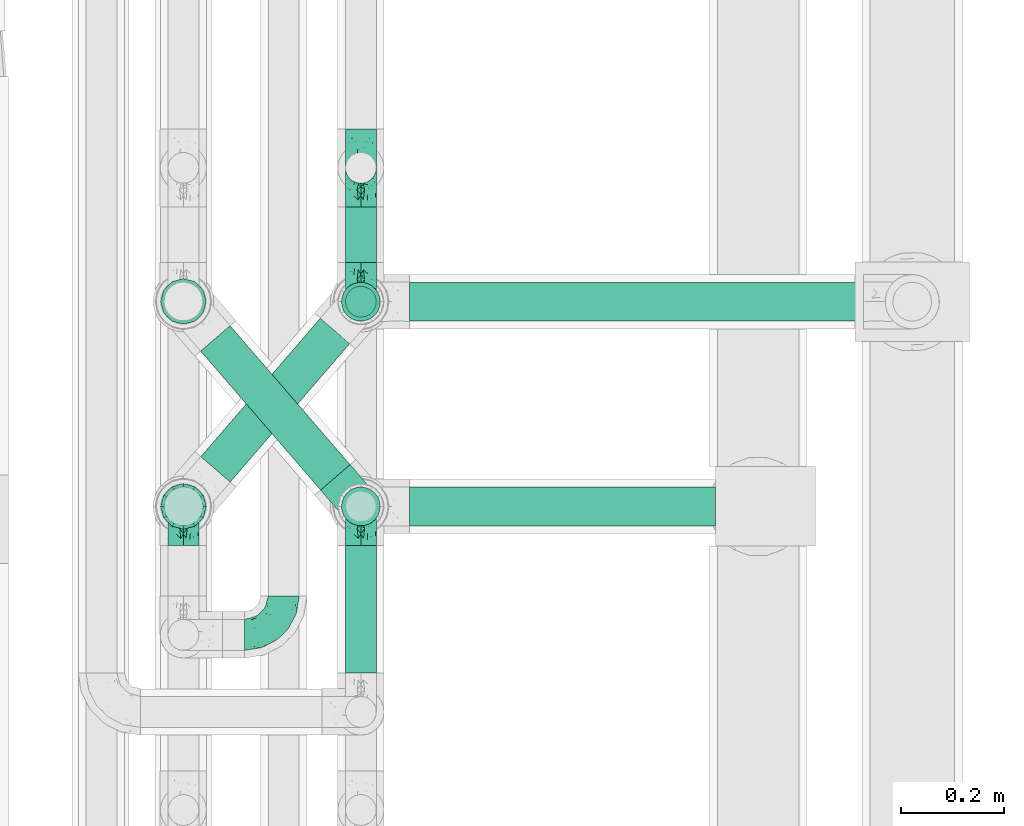
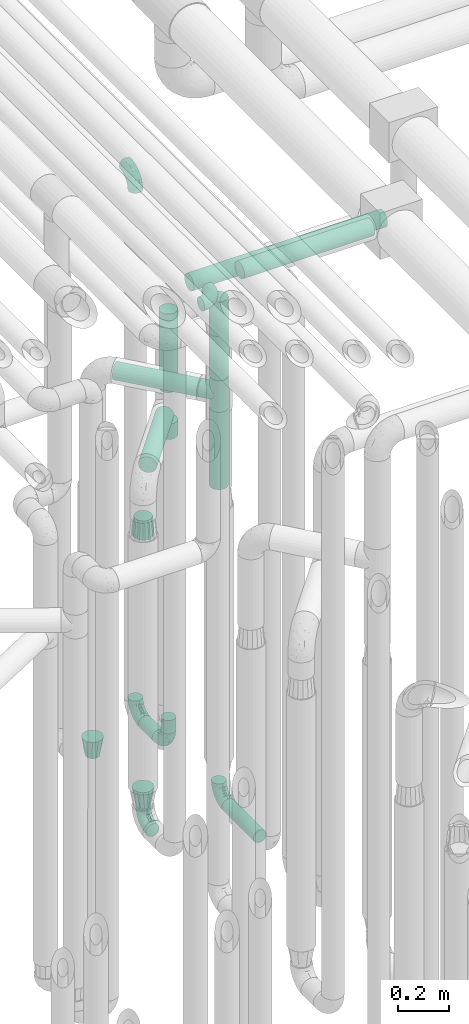
# One storey, part 624 of 824: 11 flow segments, 10 flow fittings.
"""IFC2X3 building model written with IfcOpenShell, lengths in millimetres."""

from ifc_helpers import new_model, entity, si_unit, converted_unit, derived_unit, direction, frame, origin, origin_2d_with_axis, place, context, subcontext, project, spatial, circle, extrude, faceted_brep, source, transform, mapped, material, type_object, type_shapes, element, save


model = new_model("IFC2X3")

# Units and contexts
model_context = context("Model", 3, precision=0.01, world=origin(), true_north=direction((6.12303176911189e-17, 1.0)))
body_context = subcontext(model_context, "Body", "Model", "MODEL_VIEW")
ifc_project = project(units=[si_unit("LENGTHUNIT", "METRE", prefix="MILLI"), si_unit("AREAUNIT", "SQUARE_METRE"), si_unit("VOLUMEUNIT", "CUBIC_METRE"), converted_unit("PLANEANGLEUNIT", "DEGREE", entity("IfcRatioMeasure", 0.0174532925199433), si_unit("PLANEANGLEUNIT", "RADIAN"), dimensions=[0, 0, 0, 0, 0, 0, 0]), si_unit("MASSUNIT", "GRAM", prefix="KILO"), derived_unit("MASSDENSITYUNIT", [(si_unit("MASSUNIT", "GRAM", prefix="KILO"), 1), (si_unit("LENGTHUNIT", "METRE"), -3)]), derived_unit("MOMENTOFINERTIAUNIT", [(si_unit("LENGTHUNIT", "METRE"), 4)]), si_unit("TIMEUNIT", "SECOND"), si_unit("FREQUENCYUNIT", "HERTZ"), si_unit("THERMODYNAMICTEMPERATUREUNIT", "DEGREE_CELSIUS"), derived_unit("THERMALTRANSMITTANCEUNIT", [(si_unit("MASSUNIT", "GRAM", prefix="KILO"), 1), (si_unit("THERMODYNAMICTEMPERATUREUNIT", "KELVIN"), -1), (si_unit("TIMEUNIT", "SECOND"), -3)]), derived_unit("VOLUMETRICFLOWRATEUNIT", [(si_unit("LENGTHUNIT", "METRE"), 3), (si_unit("TIMEUNIT", "SECOND"), -1)]), derived_unit("MASSFLOWRATEUNIT", [(si_unit("MASSUNIT", "GRAM", prefix="KILO"), 1), (si_unit("TIMEUNIT", "SECOND"), -1)]), derived_unit("ROTATIONALFREQUENCYUNIT", [(si_unit("TIMEUNIT", "SECOND"), -1)]), si_unit("ELECTRICCURRENTUNIT", "AMPERE"), si_unit("ELECTRICVOLTAGEUNIT", "VOLT"), si_unit("POWERUNIT", "WATT"), si_unit("FORCEUNIT", "NEWTON", prefix="KILO"), si_unit("ILLUMINANCEUNIT", "LUX"), si_unit("LUMINOUSFLUXUNIT", "LUMEN"), si_unit("LUMINOUSINTENSITYUNIT", "CANDELA"), derived_unit("USERDEFINED", [(si_unit("MASSUNIT", "GRAM", prefix="KILO"), -1), (si_unit("LENGTHUNIT", "METRE"), -2), (si_unit("TIMEUNIT", "SECOND"), 3), (si_unit("LUMINOUSFLUXUNIT", "LUMEN"), 1)]), derived_unit("LINEARVELOCITYUNIT", [(si_unit("LENGTHUNIT", "METRE"), 1), (si_unit("TIMEUNIT", "SECOND"), -1)]), si_unit("PRESSUREUNIT", "PASCAL"), derived_unit("USERDEFINED", [(si_unit("LENGTHUNIT", "METRE"), -2), (si_unit("MASSUNIT", "GRAM", prefix="KILO"), 1), (si_unit("TIMEUNIT", "SECOND"), -2)]), derived_unit("LINEARFORCEUNIT", [(si_unit("MASSUNIT", "GRAM", prefix="KILO"), 1), (si_unit("LENGTHUNIT", "METRE"), 1), (si_unit("TIMEUNIT", "SECOND"), -2), (si_unit("LENGTHUNIT", "METRE"), -1)]), derived_unit("PLANARFORCEUNIT", [(si_unit("MASSUNIT", "GRAM", prefix="KILO"), 1), (si_unit("LENGTHUNIT", "METRE"), 1), (si_unit("TIMEUNIT", "SECOND"), -2), (si_unit("LENGTHUNIT", "METRE"), -2)])], contexts=[model_context])

# Site, building, storey
site_placement = place(None, origin())
site = spatial("IfcSite", under=ifc_project, at=site_placement, CompositionType="ELEMENT")
building_placement = place(site_placement, origin())
building = spatial("IfcBuilding", under=site, at=building_placement, CompositionType="ELEMENT")
storey_placement = place(building_placement, frame((0.0, 0.0, 28200.0)))
storey = spatial("IfcBuildingStorey", under=building, at=storey_placement, CompositionType="ELEMENT", Elevation=28200.0)

# Flow segments
pipe_segment_type = type_object("IfcPipeSegmentType", PredefinedType="NOTDEFINED")
flow_segment_1_placement = place(storey_placement, frame((36943.44, 12257.17, 368.4)))
element("IfcFlowSegment", 1, at=flow_segment_1_placement, inside=storey, type_object=pipe_segment_type, context=body_context, shape_type="SweptSolid", body=[
    extrude(circle(Radius=30.0, at=origin_2d_with_axis()), frame((31.6, 0.0, 31.6), z_axis=(0.0, 1.0, 0.0), x_axis=(1.0, 0.0, 0.0)), (0.0, 0.0, 1.0), 247.999981999989),
])
flow_segment_2_placement = place(storey_placement, frame((36943.44, 13055.64, 368.4)))
element("IfcFlowSegment", 2, at=flow_segment_2_placement, inside=storey, type_object=pipe_segment_type, context=body_context, shape_type="SweptSolid", body=[
    extrude(circle(Radius=30.0, at=origin_2d_with_axis()), frame((31.6, 0.0, 31.6), z_axis=(0.0, 1.0, 0.0), x_axis=(-1.0, 0.0, 0.0)), (0.0, 0.0, 1.0), 108.562571608464),
])
flow_segment_3_placement = place(storey_placement, frame((36943.44, 12948.05, 476.0)))
element("IfcFlowSegment", 3, at=flow_segment_3_placement, inside=storey, type_object=pipe_segment_type, context=body_context, shape_type="SweptSolid", body=[
    extrude(circle(Radius=30.0, at=origin_2d_with_axis()), frame((31.6, 31.6, 0.0)), (0.0, 0.0, 1.0), 64.0000000000244),
])
flow_segment_4_placement = place(storey_placement, frame((36935.69, 12940.3, 2126.0)))
element("IfcFlowSegment", 4, at=flow_segment_4_placement, inside=storey, type_object=pipe_segment_type, context=body_context, shape_type="SweptSolid", body=[
    extrude(circle(Radius=37.75, at=origin_2d_with_axis()), frame((39.35, 39.35, 0.0), z_axis=(0.0, 0.0, 1.0), x_axis=(-1.0, 0.0, 0.0)), (0.0, 0.0, 1.0), 378.999999999992),
])
flow_segment_5_placement = place(storey_placement, frame((37070.03, 12940.3, 2560.65)))
element("IfcFlowSegment", 5, at=flow_segment_5_placement, inside=storey, type_object=pipe_segment_type, context=body_context, shape_type="SweptSolid", body=[
    extrude(circle(Radius=37.75, at=origin_2d_with_axis()), frame((0.0, 39.35, 39.35), z_axis=(1.0, 0.0, 0.0), x_axis=(0.0, -1.0, 0.0)), (0.0, 0.0, 1.0), 883.265688415884),
])
flow_segment_6_placement = place(storey_placement, frame((36935.69, 12541.83, 2426.0)))
element("IfcFlowSegment", 6, at=flow_segment_6_placement, inside=storey, type_object=pipe_segment_type, context=body_context, shape_type="SweptSolid", body=[
    extrude(circle(Radius=37.75, at=origin_2d_with_axis()), frame((39.35, 39.35, 0.0), z_axis=(-2.14503310068031e-08, 1.89574983412965e-07, 1.0), x_axis=(-1.0, 0.0, -2.14503310068034e-08)), (0.0, 0.0, 1.0), 378.904960794338),
])
flow_segment_7_placement = place(storey_placement, frame((37070.03, 12541.83, 2860.56)))
element("IfcFlowSegment", 7, at=flow_segment_7_placement, inside=storey, type_object=pipe_segment_type, context=body_context, shape_type="SweptSolid", body=[
    extrude(circle(Radius=37.75, at=origin_2d_with_axis()), frame((0.0, 39.35, 39.35), z_axis=(1.0, 0.0, 0.0), x_axis=(0.0, 1.0, 0.0)), (0.0, 0.0, 1.0), 595.765098762424),
])
flow_segment_8_placement = place(storey_placement, frame((36661.57, 12611.47, 2310.65)))
element("IfcFlowSegment", 8, at=flow_segment_8_placement, inside=storey, type_object=pipe_segment_type, context=body_context, shape_type="SweptSolid", body=[
    extrude(circle(Radius=37.75, at=origin_2d_with_axis()), frame((30.17, 296.83, 39.35), z_axis=(0.65359148401651, -0.756847522306242, 0.0), x_axis=(-0.756847522306242, -0.65359148401651, 0.0)), (0.0, 0.0, 1.0), 357.482862990724),
])
flow_segment_9_placement = place(storey_placement, frame((36935.69, 12541.83, 1900.0)))
element("IfcFlowSegment", 9, at=flow_segment_9_placement, inside=storey, type_object=pipe_segment_type, context=body_context, shape_type="SweptSolid", body=[
    extrude(circle(Radius=37.75, at=origin_2d_with_axis()), frame((39.35, 39.35, 0.0), z_axis=(0.0, 0.0, 1.0), x_axis=(-1.0, 0.0, 0.0)), (0.0, 0.0, 1.0), 374.000000000002),
])
flow_segment_10_placement = place(storey_placement, frame((36661.85, 12626.98, 2010.65)))
element("IfcFlowSegment", 10, at=flow_segment_10_placement, inside=storey, type_object=pipe_segment_type, context=body_context, shape_type="SweptSolid", body=[
    extrude(circle(Radius=37.75, at=origin_2d_with_axis()), frame((30.17, 26.27, 39.35), z_axis=(0.653617255256322, 0.756825266247891, 0.0), x_axis=(0.756825266247891, -0.653617255256322, 0.0)), (0.0, 0.0, 1.0), 356.010747294406),
])
flow_segment_11_placement = place(storey_placement, frame((36935.69, 12940.3, 1900.0)))
element("IfcFlowSegment", 11, at=flow_segment_11_placement, inside=storey, type_object=pipe_segment_type, context=body_context, shape_type="SweptSolid", body=[
    extrude(circle(Radius=37.75, at=origin_2d_with_axis()), frame((39.35, 39.35, 0.0), z_axis=(0.0, 0.0, 1.0), x_axis=(-1.0, 0.0, 0.0)), (0.0, 0.0, 1.0), 74.0000000000005),
])

# Flow fittings
ifc_material = material()
pipe_fitting_type_1 = type_object("IfcPipeFittingType", PredefinedType="NOTDEFINED", material=ifc_material)
shared_shape_1 = source(origin(), body_context, "Body", "Brep", [
    faceted_brep([(-76.0, 15.07, -26.11), (-76.0, 7.8, -29.12), (-76.0, 0.0, -30.15), (-76.0, -7.8, -29.12), (-76.0, -15.08, -26.11), (-76.0, -21.32, -21.32), (-76.0, -26.11, -15.08), (-76.0, -29.12, -7.8), (-76.0, -30.15, 0.0), (-76.0, -29.12, 7.8), (-76.0, -26.11, 15.07), (-76.0, -21.32, 21.32), (-76.0, -15.08, 26.11), (-76.0, -7.8, 29.12), (-76.0, 0.0, 30.15), (-76.0, 7.8, 29.12), (-76.0, 15.07, 26.11), (-76.0, 21.32, 21.32), (-76.0, 26.11, 15.07), (-76.0, 29.12, 7.8), (-76.0, 30.15, 0.0), (-76.0, 29.12, -7.8), (-76.0, 26.11, -15.08), (-76.0, 21.32, -21.32), (0.0, 76.0, -30.15), (-7.8, 76.0, -29.12), (-15.07, 76.0, -26.11), (-21.32, 76.0, -21.32), (-26.11, 76.0, -15.08), (-29.12, 76.0, -7.8), (-30.15, 76.0, 0.0), (-29.12, 76.0, 7.8), (-26.11, 76.0, 15.07), (-21.32, 76.0, 21.32), (-15.07, 76.0, 26.11), (-7.8, 76.0, 29.12), (0.0, 76.0, 30.15), (7.8, 76.0, 29.12), (15.08, 76.0, 26.11), (21.32, 76.0, 21.32), (26.11, 76.0, 15.07), (29.12, 76.0, 7.8), (30.15, 76.0, 0.0), (29.12, 76.0, -7.8), (26.11, 76.0, -15.08), (21.32, 76.0, -21.32), (15.08, 76.0, -26.11), (7.8, 76.0, -29.12), (10.79, 31.43, 21.07), (4.32, 31.7, 25.72), (1.65, 15.19, 19.92), (-61.17, -27.8, 0.0), (-51.1, -25.49, 9.84), (-56.14, -10.61, 27.27), (-31.7, -4.32, 25.72), (-39.75, 1.72, 29.41), (-43.2, -24.95, 0.0), (-1.86, 1.86, 0.0), (4.49, 7.65, 5.78), (-7.82, -4.61, 5.83), (-56.21, -22.79, 17.21), (-58.98, -3.38, 29.7), (-53.96, 5.6, 30.07), (-10.86, 10.86, 25.48), (-17.2, -2.6, 20.44), (-49.15, -16.01, 22.7), (-22.18, -14.24, 7.99), (-28.4, -17.42, 0.0), (-13.61, -9.88, 0.0), (-39.0, 23.48, 27.76), (-58.76, 12.54, 28.36), (-41.61, 15.41, 29.48), (16.01, 49.15, 22.7), (-58.55, 25.93, 19.53), (-51.53, 33.5, 13.51), (-64.92, 28.76, 12.4), (-7.48, 23.14, 28.25), (-1.72, 39.75, 29.41), (-12.04, 27.88, 29.88), (-63.91, 18.81, 24.52), (-11.63, 65.16, 28.18), (-4.97, 57.02, 30.05), (9.88, 13.61, 0.0), (-62.5, 31.74, 5.02), (-45.17, 30.98, 21.2), (-21.78, 9.76, 28.58), (10.61, 56.14, 27.27), (-32.09, 54.42, 13.26), (22.79, 56.21, 17.21), (15.38, 31.17, 15.63), (25.49, 51.1, 9.84), (21.84, 36.35, 5.92), (24.95, 43.2, 0.0), (3.38, 58.98, 29.7), (-31.17, -15.38, 15.63), (-39.39, 41.78, 15.45), (-34.56, 41.13, 20.79), (-39.81, -23.25, 5.49), (27.8, 61.17, 0.0), (-31.74, 62.5, 5.02), (-53.07, 36.29, 0.0), (-42.95, 42.95, 7.29), (-36.29, 53.07, 0.0), (-19.83, 58.51, 24.79), (-25.48, 60.2, 19.41), (-14.53, 50.96, 28.57), (-13.31, 37.09, 30.07), (-26.16, 40.06, 26.4), (-32.43, -10.35, 21.9), (17.42, 28.4, 0.0), (14.24, 22.18, 7.99), (-38.67, 9.72, 30.15), (-24.66, 17.36, 30.09), (-37.08, 31.49, 24.99), (-49.27, 22.83, 25.24), (-20.8, 38.81, 28.63), (-27.58, 27.58, 29.2), (-36.07, -20.23, 10.71), (-15.19, -6.16, 14.9), (6.6, 15.4, 14.49), (-2.51, 2.51, 11.35), (-65.16, 11.63, -28.18), (-49.15, -16.01, -22.7), (-57.02, 4.97, -30.05), (-25.93, 58.55, -19.53), (-33.5, 51.53, -13.51), (-28.76, 64.92, -12.4), (-60.2, 25.48, -19.41), (-58.51, 19.83, -24.79), (4.61, 7.82, -5.83), (-7.65, -4.49, -5.78), (-2.51, 2.51, -11.35), (-62.5, 31.74, -5.02), (-50.96, 14.53, -28.57), (-37.09, 13.31, -30.07), (-42.95, 42.95, -7.29), (25.49, 51.1, -9.84), (22.79, 56.21, -17.21), (-40.06, 26.16, -26.4), (3.38, 58.98, -29.7), (-5.6, 53.96, -30.07), (-27.88, 12.04, -29.88), (-9.76, 21.78, -28.58), (-23.14, 7.48, -28.25), (-51.1, -25.49, -9.84), (15.38, 31.17, -15.63), (16.01, 49.15, -22.7), (-23.48, 39.0, -27.76), (-12.54, 58.76, -28.36), (-15.41, 41.61, -29.48), (-56.21, -22.79, -17.21), (-9.72, 38.67, -30.15), (-17.36, 24.66, -30.09), (-22.18, -14.24, -7.99), (-41.13, 34.56, -20.79), (-31.74, 62.5, -5.02), (-58.98, -3.38, -29.7), (-31.17, -15.38, -15.63), (-56.14, -10.61, -27.27), (14.24, 22.18, -7.99), (23.25, 39.81, -5.49), (-31.49, 37.08, -24.99), (-15.19, -6.16, -14.9), (1.65, 15.19, -19.92), (-18.81, 63.91, -24.52), (-32.59, -11.62, -20.84), (-31.7, -4.32, -25.72), (-17.2, -2.6, -20.44), (-39.75, 1.72, -29.41), (-54.42, 32.09, -13.26), (-30.98, 45.17, -21.2), (10.61, 56.14, -27.27), (10.23, 31.31, -21.52), (4.32, 31.7, -25.72), (-41.78, 39.39, -15.45), (-1.72, 39.75, -29.41), (-36.35, -21.84, -5.92), (-22.83, 49.27, -25.24), (-38.81, 20.8, -28.63), (-27.58, 27.58, -29.2), (-10.86, 10.86, -25.48), (20.23, 36.07, -10.71), (6.6, 15.4, -14.49)], [[[0, 1, 2, 3, 4, 5, 6, 7, 8, 9, 10, 11, 12, 13, 14, 15, 16, 17, 18, 19, 20, 21, 22, 23]], [[24, 25, 26, 27, 28, 29, 30, 31, 32, 33, 34, 35, 36, 37, 38, 39, 40, 41, 42, 43, 44, 45, 46, 47]], [[48, 49, 50]], [[51, 52, 9]], [[53, 54, 55]], [[9, 52, 10]], [[56, 52, 51]], [[57, 58, 59]], [[11, 10, 60]], [[14, 61, 62]], [[63, 54, 64]], [[65, 12, 11]], [[65, 53, 12]], [[66, 67, 68]], [[69, 70, 71]], [[72, 39, 38]], [[73, 74, 75]], [[15, 70, 16]], [[76, 77, 78]], [[16, 79, 17]], [[13, 61, 14]], [[35, 80, 81]], [[14, 62, 15]], [[17, 73, 18]], [[57, 82, 58]], [[20, 19, 83]], [[75, 19, 18]], [[70, 15, 62]], [[73, 84, 74]], [[78, 85, 76]], [[38, 86, 72]], [[32, 31, 87]], [[88, 89, 90]], [[91, 92, 90]], [[72, 86, 49]], [[36, 93, 37]], [[75, 83, 19]], [[36, 35, 81]], [[60, 94, 65]], [[40, 90, 41]], [[95, 96, 87]], [[88, 90, 40]], [[66, 97, 67]], [[90, 98, 41]], [[40, 39, 88]], [[99, 31, 30]], [[20, 83, 100]], [[101, 102, 100]], [[52, 60, 10]], [[102, 99, 30]], [[96, 103, 104]], [[83, 101, 100]], [[12, 53, 13]], [[104, 103, 33]], [[105, 106, 81]], [[107, 105, 103]], [[64, 54, 108]], [[80, 103, 105]], [[80, 35, 34]], [[34, 33, 103]], [[86, 38, 37]], [[109, 110, 82]], [[71, 111, 112]], [[69, 107, 113]], [[79, 73, 17]], [[114, 113, 84]], [[33, 32, 104]], [[115, 107, 116]], [[105, 115, 106]], [[93, 81, 77]], [[54, 53, 65]], [[61, 53, 55]], [[108, 94, 64]], [[54, 63, 85]], [[93, 86, 37]], [[77, 76, 49]], [[77, 49, 86]], [[49, 63, 50]], [[60, 52, 117]], [[65, 11, 60]], [[39, 72, 88]], [[89, 88, 72]], [[71, 70, 62]], [[79, 70, 114]], [[103, 96, 107]], [[69, 113, 114]], [[112, 106, 116]], [[77, 81, 106]], [[112, 116, 71]], [[112, 55, 85]], [[64, 50, 63]], [[57, 59, 68]], [[32, 87, 104]], [[96, 104, 87]], [[94, 118, 64]], [[50, 119, 89]], [[50, 64, 118]], [[50, 89, 48]], [[81, 93, 36]], [[86, 93, 77]], [[53, 61, 13]], [[62, 61, 55]], [[71, 62, 111]], [[69, 71, 116]], [[95, 101, 74]], [[99, 101, 87]], [[118, 66, 59]], [[117, 97, 66]], [[117, 66, 94]], [[91, 89, 110]], [[91, 110, 109]], [[110, 89, 119]], [[9, 8, 51]], [[98, 90, 92]], [[98, 42, 41]], [[101, 83, 74]], [[101, 99, 102]], [[87, 31, 99]], [[62, 55, 111]], [[55, 112, 111]], [[107, 69, 116]], [[70, 69, 114]], [[107, 96, 113]], [[84, 113, 96]], [[84, 96, 95]], [[114, 84, 73]], [[70, 79, 16]], [[73, 79, 114]], [[54, 85, 55]], [[76, 85, 63]], [[49, 76, 63]], [[77, 106, 78]], [[106, 112, 78]], [[85, 78, 112]], [[73, 75, 18]], [[83, 75, 74]], [[103, 80, 34]], [[81, 80, 105]], [[101, 95, 87]], [[84, 95, 74]], [[106, 115, 116]], [[105, 107, 115]], [[120, 59, 58]], [[82, 110, 58]], [[119, 58, 110]], [[118, 59, 120]], [[66, 68, 59]], [[54, 65, 108]], [[94, 108, 65]], [[66, 118, 94]], [[50, 118, 120]], [[50, 120, 119]], [[119, 120, 58]], [[89, 72, 48]], [[49, 48, 72]], [[60, 117, 94]], [[117, 52, 97]], [[52, 56, 97]], [[67, 97, 56]], [[92, 91, 109]], [[89, 91, 90]], [[121, 1, 0]], [[122, 5, 4]], [[2, 1, 123]], [[124, 125, 126]], [[127, 128, 23]], [[129, 130, 131]], [[100, 132, 20]], [[133, 134, 123]], [[135, 100, 102]], [[136, 137, 44]], [[133, 128, 138]], [[24, 139, 140]], [[141, 142, 143]], [[121, 128, 133]], [[6, 144, 7]], [[137, 145, 146]], [[144, 51, 7]], [[147, 148, 149]], [[144, 6, 150]], [[149, 151, 152]], [[153, 68, 67]], [[154, 128, 127]], [[30, 155, 102]], [[43, 42, 98]], [[156, 3, 2]], [[157, 144, 150]], [[158, 4, 3]], [[24, 140, 25]], [[155, 135, 102]], [[159, 160, 109]], [[30, 29, 155]], [[147, 138, 161]], [[27, 124, 28]], [[57, 129, 82]], [[162, 163, 131]], [[27, 26, 164]], [[148, 26, 25]], [[165, 166, 167]], [[24, 47, 139]], [[143, 168, 141]], [[22, 21, 169]], [[125, 124, 170]], [[148, 25, 140]], [[46, 146, 171]], [[158, 122, 4]], [[0, 23, 128]], [[1, 121, 123]], [[109, 82, 159]], [[45, 44, 137]], [[146, 46, 45]], [[136, 43, 98]], [[132, 21, 20]], [[136, 98, 92]], [[172, 173, 146]], [[46, 171, 47]], [[43, 136, 44]], [[174, 154, 169]], [[171, 173, 175]], [[6, 5, 150]], [[126, 29, 28]], [[176, 56, 144]], [[122, 158, 166]], [[164, 124, 27]], [[177, 161, 170]], [[23, 22, 127]], [[178, 138, 179]], [[133, 178, 134]], [[156, 123, 168]], [[156, 158, 3]], [[168, 143, 166]], [[168, 166, 158]], [[166, 180, 167]], [[173, 171, 146]], [[139, 171, 175]], [[172, 145, 163]], [[173, 180, 142]], [[5, 122, 150]], [[157, 150, 122]], [[137, 136, 181]], [[146, 45, 137]], [[149, 148, 140]], [[164, 148, 177]], [[128, 154, 138]], [[147, 161, 177]], [[152, 134, 179]], [[168, 123, 134]], [[152, 179, 149]], [[152, 175, 142]], [[57, 130, 129]], [[157, 165, 167]], [[22, 169, 127]], [[154, 127, 169]], [[163, 167, 180]], [[162, 157, 167]], [[173, 163, 180]], [[182, 163, 145]], [[123, 156, 2]], [[158, 156, 168]], [[171, 139, 47]], [[140, 139, 175]], [[149, 140, 151]], [[147, 149, 179]], [[174, 135, 125]], [[132, 135, 169]], [[176, 157, 153]], [[176, 153, 67]], [[153, 157, 162]], [[182, 159, 129]], [[181, 160, 159]], [[181, 159, 145]], [[51, 144, 56]], [[51, 8, 7]], [[135, 132, 100]], [[169, 21, 132]], [[126, 155, 29]], [[135, 155, 125]], [[140, 175, 151]], [[175, 152, 151]], [[138, 147, 179]], [[148, 147, 177]], [[138, 154, 161]], [[170, 161, 154]], [[170, 154, 174]], [[177, 170, 124]], [[148, 164, 26]], [[124, 164, 177]], [[173, 142, 175]], [[143, 142, 180]], [[166, 143, 180]], [[168, 134, 141]], [[134, 152, 141]], [[142, 141, 152]], [[124, 126, 28]], [[155, 126, 125]], [[128, 121, 0]], [[123, 121, 133]], [[135, 174, 169]], [[170, 174, 125]], [[134, 178, 179]], [[133, 138, 178]], [[130, 153, 162]], [[68, 153, 130]], [[57, 68, 130]], [[182, 129, 131]], [[159, 82, 129]], [[157, 122, 165]], [[166, 165, 122]], [[163, 162, 167]], [[162, 131, 130]], [[145, 172, 146]], [[163, 173, 172]], [[159, 182, 145]], [[131, 163, 182]], [[56, 176, 67]], [[157, 176, 144]], [[137, 181, 145]], [[181, 136, 160]], [[136, 92, 160]], [[109, 160, 92]]]),
])
type_shapes(pipe_fitting_type_1, [shared_shape_1])
for number, where, z_axis, x_axis in (
    (12, (36975.03, 12581.17, 400.0), (1.0, 0.0, 0.0), (0.0, 1.0, 0.0)),
    (13, (36975.03, 13240.2, 400.0), (-1.0, 0.0, 0.0), (0.0, 0.0, -1.0)),
    (14, (36975.03, 12979.64, 400.0), (-1.0, 0.0, 0.0), (0.0, -1.0, 0.0)),
    (15, (36975.03, 13240.2, 3000.0), (-1.0, 0.0, 0.0), (0.0, 0.0, 1.0)),
):
    element("IfcFlowFitting", number, at=place(storey_placement, frame(where, z_axis=z_axis, x_axis=x_axis)), inside=storey, type_object=pipe_fitting_type_1, material=ifc_material, context=body_context, shape_type="MappedRepresentation", body=[
        mapped(shared_shape_1, transform((0.0, 0.0, 0.0), scale=1.0)),
    ])
flow_fitting_1_placement = place(storey_placement, frame((36825.03, 12331.17, 3000.0)))
element("IfcFlowFitting", 16, at=flow_fitting_1_placement, inside=storey, type_object=pipe_fitting_type_1, material=ifc_material, context=body_context, shape_type="MappedRepresentation", body=[
    mapped(shared_shape_1, transform((0.0, 0.0, 0.0), scale=1.0)),
])
flow_fitting_2_placement = place(storey_placement, frame((36629.64, 12581.17, 400.0), z_axis=(0.999999979696238, 0.0, -0.000201513087664095), x_axis=(0.0, 1.0, 0.0)))
element("IfcFlowFitting", 17, at=flow_fitting_2_placement, inside=storey, type_object=pipe_fitting_type_1, material=ifc_material, context=body_context, shape_type="MappedRepresentation", body=[
    mapped(shared_shape_1, transform((0.0, 0.0, 0.0), scale=1.0)),
])
pipe_fitting_type_2 = type_object("IfcPipeFittingType", PredefinedType="NOTDEFINED", material=ifc_material)
shared_shape_2 = source(origin(), body_context, "Body", "Brep", [
    faceted_brep([(-76.0, 9.85, -36.75), (-76.0, 0.0, -38.05), (-76.0, -9.85, -36.75), (-76.0, -19.03, -32.95), (-76.0, -22.97, -29.93), (-76.0, -26.91, -26.91), (-76.0, -29.93, -22.97), (-76.0, -32.95, -19.03), (-76.0, -34.85, -14.44), (-76.0, -36.75, -9.85), (-76.0, -38.05, 0.0), (-76.0, -36.75, 9.85), (-76.0, -34.85, 14.44), (-76.0, -32.95, 19.02), (-76.0, -29.93, 22.97), (-76.0, -26.91, 26.91), (-76.0, -22.97, 29.93), (-76.0, -19.03, 32.95), (-76.0, -9.85, 36.75), (-76.0, 0.0, 38.05), (-76.0, 9.85, 36.75), (-76.0, 19.02, 32.95), (-76.0, 26.91, 26.91), (-76.0, 32.95, 19.02), (-76.0, 36.75, 9.85), (-76.0, 38.05, 0.0), (-76.0, 36.75, -9.85), (-76.0, 32.95, -19.03), (-76.0, 26.91, -26.91), (-76.0, 19.02, -32.95), (76.0, 26.91, -26.91), (76.0, 32.95, -19.03), (76.0, 36.75, -9.85), (76.0, 38.05, 0.0), (76.0, 36.75, 9.85), (76.0, 32.95, 19.02), (76.0, 26.91, 26.91), (76.0, 19.02, 32.95), (76.0, 9.85, 36.75), (76.0, 0.0, 38.05), (76.0, -9.85, 36.75), (76.0, -19.03, 32.95), (76.0, -22.97, 29.93), (76.0, -26.91, 26.91), (76.0, -29.93, 22.97), (76.0, -32.95, 19.02), (76.0, -34.85, 14.44), (76.0, -36.75, 9.85), (76.0, -38.05, 0.0), (76.0, -36.75, -9.85), (76.0, -34.85, -14.44), (76.0, -32.95, -19.03), (76.0, -29.93, -22.97), (76.0, -26.91, -26.91), (76.0, -22.97, -29.93), (76.0, -19.03, -32.95), (76.0, -9.85, -36.75), (76.0, 0.0, -38.05), (76.0, 9.85, -36.75), (76.0, 19.02, -32.95), (36.99, -36.99, 8.94), (38.05, -38.05, 0.0), (-36.99, -36.99, 8.94), (-38.05, -38.05, 0.0), (35.51, -35.51, 12.97), (34.04, -34.04, 17.0), (18.81, -18.81, 33.08), (29.74, -29.74, 23.73), (24.56, -24.56, 29.06), (-35.51, -35.51, 12.97), (-34.04, -34.04, 17.0), (-18.81, -18.81, 33.08), (-29.74, -29.74, 23.73), (-24.56, -24.56, 29.06), (-12.7, -12.7, 35.87), (6.4, -6.4, 37.51), (12.7, -12.7, 35.87), (0.0, 0.0, 38.05), (-6.4, -6.4, 37.51), (6.4, -6.4, -37.51), (0.0, 0.0, -38.05), (12.7, -12.7, -35.87), (-24.56, -24.56, -29.06), (-6.4, -6.4, -37.51), (-35.51, -35.51, -12.97), (-36.99, -36.99, -8.94), (-29.74, -29.74, -23.73), (-12.7, -12.7, -35.87), (18.81, -18.81, -33.08), (24.56, -24.56, -29.06), (-34.04, -34.04, -17.0), (29.74, -29.74, -23.73), (36.99, -36.99, -8.94), (35.51, -35.51, -12.97), (34.04, -34.04, -17.0), (-18.81, -18.81, -33.08), (9.85, -76.0, -36.75), (19.03, -76.0, -32.95), (26.91, -76.0, -26.91), (32.95, -76.0, -19.03), (36.75, -76.0, -9.85), (38.05, -76.0, 0.0), (36.75, -76.0, 9.85), (32.95, -76.0, 19.02), (26.91, -76.0, 26.91), (19.03, -76.0, 32.95), (9.85, -76.0, 36.75), (0.0, -76.0, 38.05), (-9.85, -76.0, 36.75), (-19.02, -76.0, 32.95), (-26.91, -76.0, 26.91), (-32.95, -76.0, 19.02), (-36.75, -76.0, 9.85), (-38.05, -76.0, 0.0), (-36.75, -76.0, -9.85), (-32.95, -76.0, -19.03), (-26.91, -76.0, -26.91), (-19.02, -76.0, -32.95), (-9.85, -76.0, -36.75), (0.0, -76.0, -38.05)], [[[0, 1, 2, 3, 4, 5, 6, 7, 8, 9, 10, 11, 12, 13, 14, 15, 16, 17, 18, 19, 20, 21, 22, 23, 24, 25, 26, 27, 28, 29]], [[30, 31, 32, 33, 34, 35, 36, 37, 38, 39, 40, 41, 42, 43, 44, 45, 46, 47, 48, 49, 50, 51, 52, 53, 54, 55, 56, 57, 58, 59]], [[48, 47, 60]], [[60, 61, 48]], [[62, 10, 63]], [[47, 46, 64]], [[46, 45, 65]], [[41, 66, 42]], [[43, 67, 45, 44]], [[67, 43, 68]], [[45, 67, 65]], [[68, 43, 42]], [[11, 69, 12]], [[70, 12, 69]], [[10, 62, 11]], [[11, 62, 69]], [[71, 17, 16]], [[72, 73, 15]], [[72, 15, 14, 13]], [[15, 73, 16]], [[71, 74, 17]], [[72, 13, 70]], [[46, 65, 64]], [[42, 66, 68]], [[40, 39, 75]], [[47, 64, 60]], [[66, 41, 76]], [[75, 76, 40]], [[75, 39, 77]], [[78, 77, 19]], [[76, 41, 40]], [[23, 22, 36, 35]], [[24, 23, 35, 34]], [[21, 20, 38, 37]], [[22, 21, 37, 36]], [[38, 20, 19, 77, 39]], [[25, 24, 34, 33]], [[70, 13, 12]], [[78, 18, 74]], [[18, 78, 19]], [[18, 17, 74]], [[71, 16, 73]], [[28, 27, 31, 30]], [[26, 32, 31, 27]], [[25, 33, 32, 26]], [[29, 28, 30, 59]], [[57, 56, 79]], [[58, 57, 80, 1, 0]], [[79, 56, 81]], [[82, 5, 4]], [[59, 58, 0, 29]], [[56, 55, 81]], [[57, 79, 80]], [[80, 83, 1]], [[9, 84, 85]], [[86, 7, 6, 5]], [[83, 87, 2]], [[1, 83, 2]], [[87, 3, 2]], [[88, 54, 89]], [[54, 53, 89]], [[8, 90, 84]], [[88, 55, 54]], [[91, 89, 53]], [[52, 51, 91, 53]], [[55, 88, 81]], [[49, 92, 93]], [[92, 49, 48]], [[94, 50, 93]], [[61, 92, 48]], [[85, 63, 10]], [[51, 94, 91]], [[82, 4, 95]], [[49, 93, 50]], [[4, 3, 95]], [[5, 82, 86]], [[94, 51, 50]], [[95, 3, 87]], [[9, 8, 84]], [[90, 8, 7]], [[9, 85, 10]], [[90, 7, 86]], [[96, 97, 98, 99, 100, 101, 102, 103, 104, 105, 106, 107, 108, 109, 110, 111, 112, 113, 114, 115, 116, 117, 118, 119]], [[62, 63, 113]], [[112, 62, 113]], [[110, 109, 73]], [[72, 111, 110]], [[70, 112, 111]], [[74, 109, 108]], [[112, 70, 69, 62]], [[73, 72, 110]], [[70, 111, 72]], [[74, 71, 109]], [[107, 77, 78]], [[74, 108, 78]], [[73, 109, 71]], [[78, 108, 107]], [[75, 107, 106]], [[105, 76, 106]], [[103, 102, 65]], [[67, 104, 103]], [[68, 105, 104]], [[60, 102, 101]], [[68, 66, 105]], [[76, 75, 106]], [[66, 76, 105]], [[61, 60, 101]], [[65, 67, 103]], [[102, 60, 64, 65]], [[68, 104, 67]], [[107, 75, 77]], [[61, 101, 92]], [[100, 92, 101]], [[98, 97, 89]], [[94, 100, 99]], [[98, 91, 99]], [[81, 97, 96]], [[100, 94, 93, 92]], [[89, 91, 98]], [[94, 99, 91]], [[81, 88, 97]], [[119, 80, 79]], [[81, 96, 79]], [[89, 97, 88]], [[79, 96, 119]], [[83, 119, 118]], [[117, 87, 118]], [[115, 114, 90]], [[86, 116, 115]], [[82, 117, 116]], [[85, 114, 113]], [[82, 95, 117]], [[87, 83, 118]], [[95, 87, 117]], [[63, 85, 113]], [[90, 86, 115]], [[114, 85, 84, 90]], [[82, 116, 86]], [[119, 83, 80]]]),
])
type_shapes(pipe_fitting_type_2, [shared_shape_2])
flow_fitting_3_placement = place(storey_placement, frame((36975.03, 12580.2, 2350.0), z_axis=(0.757098240256198, 0.653301044389926, 0.0), x_axis=(0.0, 0.0, 1.0)))
element("IfcFlowFitting", 18, at=flow_fitting_3_placement, inside=storey, type_object=pipe_fitting_type_2, material=ifc_material, context=body_context, shape_type="MappedRepresentation", body=[
    mapped(shared_shape_2, transform((0.0, 0.0, 0.0), scale=1.0)),
])
pipe_fitting_type_3 = type_object("IfcPipeFittingType", PredefinedType="NOTDEFINED", material=ifc_material)
shared_shape_3 = source(origin(), body_context, "Body", "Brep", [
    faceted_brep([(89.0, -44.45, 0.0), (89.0, -42.1, -8.76), (89.0, -38.49, -22.22), (89.0, -30.36, -30.36), (89.0, -22.23, -38.49), (89.0, -11.11, -41.47), (89.0, 0.0, -44.45), (89.0, 11.11, -41.47), (89.0, 22.22, -38.49), (89.0, 30.36, -30.36), (89.0, 38.49, -22.22), (89.0, 42.1, -8.76), (89.0, 44.45, 0.0), (89.0, 42.1, 8.76), (89.0, 38.49, 22.23), (89.0, 30.36, 30.36), (89.0, 22.22, 38.49), (89.0, 11.11, 41.47), (89.0, 0.0, 44.45), (89.0, -11.11, 41.47), (89.0, -22.23, 38.49), (89.0, -30.36, 30.36), (89.0, -38.49, 22.23), (89.0, -42.1, 8.76), (0.0, 30.15, 0.0), (0.0, 27.27, -8.86), (0.0, 24.39, -17.72), (0.0, 16.85, -23.2), (0.0, 9.32, -28.67), (0.0, 0.0, -28.67), (0.0, -9.32, -28.67), (0.0, -16.85, -23.2), (0.0, -24.39, -17.72), (0.0, -27.27, -8.86), (0.0, -30.15, 0.0), (0.0, -27.27, 8.86), (0.0, -24.39, 17.72), (0.0, -16.85, 23.2), (0.0, -9.32, 28.67), (0.0, 0.0, 28.67), (0.0, 9.32, 28.67), (0.0, 16.85, 23.2), (0.0, 24.39, 17.72), (0.0, 27.27, 8.86)], [[[0, 1, 2, 3, 4, 5, 6, 7, 8, 9, 10, 11, 12, 13, 14, 15, 16, 17, 18, 19, 20, 21, 22, 23]], [[24, 25, 26, 27, 28, 29, 30, 31, 32, 33, 34, 35, 36, 37, 38, 39, 40, 41, 42, 43]], [[2, 33, 32]], [[28, 7, 29]], [[29, 5, 30]], [[24, 12, 11]], [[3, 32, 31]], [[34, 1, 0]], [[1, 34, 33]], [[8, 28, 27]], [[2, 1, 33]], [[31, 4, 3]], [[2, 32, 3]], [[11, 25, 24]], [[26, 10, 9]], [[10, 25, 11]], [[28, 8, 7]], [[27, 26, 9]], [[26, 25, 10]], [[31, 30, 4]], [[8, 27, 9]], [[29, 7, 6]], [[5, 29, 6]], [[5, 4, 30]], [[14, 43, 42]], [[38, 19, 39]], [[39, 17, 40]], [[34, 0, 23]], [[15, 42, 41]], [[24, 13, 12]], [[13, 24, 43]], [[20, 38, 37]], [[14, 13, 43]], [[41, 16, 15]], [[14, 42, 15]], [[23, 35, 34]], [[36, 22, 21]], [[22, 35, 23]], [[38, 20, 19]], [[37, 36, 21]], [[36, 35, 22]], [[41, 40, 16]], [[20, 37, 21]], [[39, 19, 18]], [[17, 39, 18]], [[17, 16, 40]]]),
])
type_shapes(pipe_fitting_type_3, [shared_shape_3])
for number, where, z_axis, x_axis in (
    (19, (36629.64, 12980.2, 476.0), (1.0, 0.0, 0.0), (0.0, 0.0, 1.0)),
    (20, (36629.66, 12581.17, 476.0), (0.0, 1.0, 0.0), (0.000201513087664095, 0.0, 0.999999979696238)),
):
    element("IfcFlowFitting", number, at=place(storey_placement, frame(where, z_axis=z_axis, x_axis=x_axis)), inside=storey, type_object=pipe_fitting_type_3, material=ifc_material, context=body_context, shape_type="MappedRepresentation", body=[
        mapped(shared_shape_3, transform((0.0, 0.0, 0.0), scale=1.0)),
    ])
pipe_fitting_type_4 = type_object("IfcPipeFittingType", PredefinedType="NOTDEFINED", material=ifc_material)
shared_shape_4 = source(origin(), body_context, "Body", "Brep", [
    faceted_brep([(89.0, 38.05, 0.0), (89.0, 35.5, 9.51), (89.0, 32.95, 19.03), (89.0, 25.99, 25.99), (89.0, 19.02, 32.95), (89.0, 9.51, 35.5), (89.0, 0.0, 38.05), (89.0, -9.51, 35.5), (89.0, -19.03, 32.95), (89.0, -25.99, 25.99), (89.0, -32.95, 19.03), (89.0, -35.5, 9.51), (89.0, -38.05, 0.0), (89.0, -35.5, -9.51), (89.0, -32.95, -19.02), (89.0, -25.99, -25.99), (89.0, -19.03, -32.95), (89.0, -9.51, -35.5), (89.0, 0.0, -38.05), (89.0, 9.51, -35.5), (89.0, 19.02, -32.95), (89.0, 25.99, -25.99), (89.0, 32.95, -19.03), (89.0, 35.5, -9.51), (0.0, -38.49, 22.22), (0.0, -30.36, 30.36), (0.0, -22.22, 38.49), (0.0, -11.11, 41.47), (0.0, 0.0, 44.45), (0.0, 11.11, 41.47), (0.0, 22.23, 38.49), (0.0, 30.36, 30.36), (0.0, 38.49, 22.22), (0.0, 41.96, 9.31), (0.0, 44.45, 0.0), (0.0, 41.47, -11.11), (0.0, 38.49, -22.23), (0.0, 30.36, -30.36), (0.0, 22.23, -38.49), (0.0, 11.11, -41.47), (0.0, 0.0, -44.45), (0.0, -11.11, -41.47), (0.0, -22.23, -38.49), (0.0, -30.36, -30.36), (0.0, -38.49, -22.23), (0.0, -41.96, -9.31), (0.0, -44.45, 0.0), (0.0, -41.47, 11.11)], [[[0, 1, 2, 3, 4, 5, 6, 7, 8, 9, 10, 11, 12, 13, 14, 15, 16, 17, 18, 19, 20, 21, 22, 23]], [[24, 25, 26, 27, 28, 29, 30, 31, 32, 33, 34, 35, 36, 37, 38, 39, 40, 41, 42, 43, 44, 45, 46, 47]], [[23, 22, 36, 35, 34, 0]], [[39, 38, 20, 19, 18, 40]], [[38, 37, 36, 22, 21, 20]], [[43, 42, 16, 15, 14, 44]], [[41, 40, 18, 17, 16, 42]], [[12, 46, 45, 44, 14, 13]], [[11, 10, 24, 47, 46, 12]], [[27, 26, 8, 7, 6, 28]], [[26, 25, 24, 10, 9, 8]], [[31, 30, 4, 3, 2, 32]], [[29, 28, 6, 5, 4, 30]], [[0, 34, 33, 32, 2, 1]]]),
])
type_shapes(pipe_fitting_type_4, [shared_shape_4])
flow_fitting_4_placement = place(storey_placement, frame((36629.92, 12581.17, 1781.0), z_axis=(0.0, 1.0, 0.0), x_axis=(0.000201513087669316, 0.0, 0.999999979696238)))
element("IfcFlowFitting", 21, at=flow_fitting_4_placement, inside=storey, type_object=pipe_fitting_type_4, material=ifc_material, context=body_context, shape_type="MappedRepresentation", body=[
    mapped(shared_shape_4, transform((0.0, 0.0, 0.0), scale=1.0)),
])

save(model, "model.ifc")
